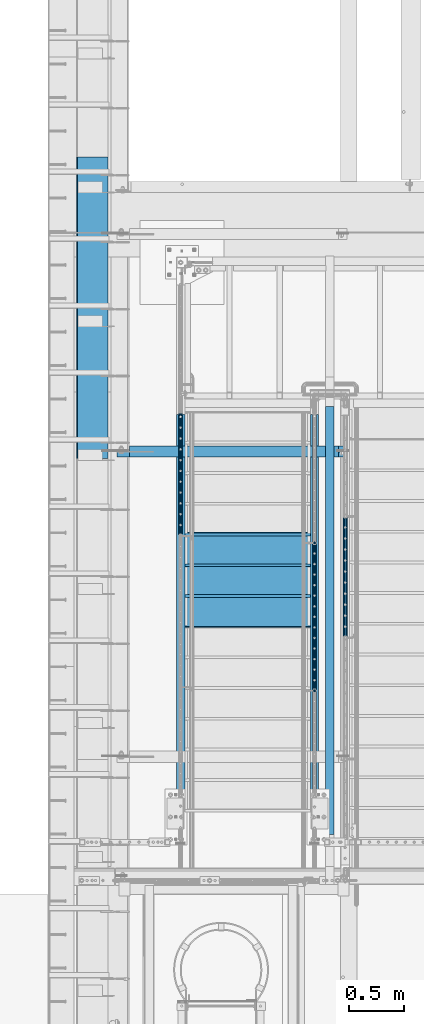
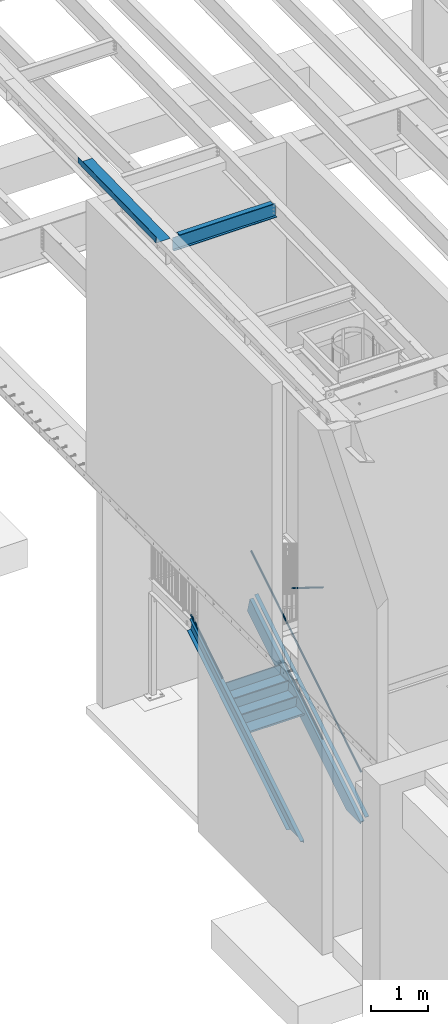
# One storey, part 1091 of 1763: 7 members, 5 beams, 7 elements without a shape of their own.
"""IFC2X3 building model written with IfcOpenShell, lengths in millimetres."""

import ifcopenshell
import ifcopenshell.guid

model = None  # the IFC model being written
_history = None  # IfcOwnerHistory: only IFC2X3 demands one
_inside = {}  # id of a spatial element -> (the spatial element, [elements in it])
_under = {}  # id of a project, library or spatial element -> (it, [spatial elements below it])
_declared = {}  # id of a project -> (the project, [libraries it declares])
_typed = {}  # id of a type object -> (the type object, [elements of that type])
_made_of = {}  # id of a material, layer set ... -> (it, [elements and type objects made of it])


def new_model(schema):
    """Start an empty IFC model of exactly this schema.

    Asked for "IFC4X3", IfcOpenShell would pick the latest addendum, in which some entities
    have other attributes; the version numbers below select the first issue.
    IFC2X3 requires an IfcOwnerHistory on every rooted entity: one is made here for all.
    """
    global model, _history
    if schema == "IFC4X3":
        model = ifcopenshell.file(schema_version=(4, 3, 0, 0))
    else:
        model = ifcopenshell.file(schema=schema)
    _inside.clear()
    _under.clear()
    _declared.clear()
    _typed.clear()
    _made_of.clear()
    _history = None
    if model.schema == "IFC2X3":
        org = make("IfcOrganization", Name="unknown")
        user = make(
            "IfcPersonAndOrganization",
            ThePerson=make("IfcPerson", FamilyName="unknown"),
            TheOrganization=org,
        )
        app = make(
            "IfcApplication",
            ApplicationDeveloper=org,
            Version="unknown",
            ApplicationFullName="unknown",
            ApplicationIdentifier="unknown",
        )
        _history = make(
            "IfcOwnerHistory",
            OwningUser=user,
            OwningApplication=app,
            ChangeAction="ADDED",
            CreationDate=0,
        )
    return model


def make(cls, **values):
    """One entity of the class cls with the attributes given. An attribute that is None is left unset."""
    return model.create_entity(
        cls, **{name: value for name, value in values.items() if value is not None}
    )


def rooted(cls, **values):
    """An entity with a GlobalId (a new one), such as an element, a storey or a relation."""
    return make(cls, GlobalId=ifcopenshell.guid.new(), OwnerHistory=_history, **values)


def si_unit(unit_type, name, prefix=None):
    """IfcSIUnit, for example si_unit("LENGTHUNIT", "METRE", prefix="MILLI")."""
    return make("IfcSIUnit", UnitType=unit_type, Prefix=prefix, Name=name)


def assignment(units):
    """IfcUnitAssignment: the units of a project."""
    return None if units is None else make("IfcUnitAssignment", Units=units)


def point(xyz):
    """IfcCartesianPoint."""
    return None if xyz is None else make("IfcCartesianPoint", Coordinates=xyz)


def direction(xyz):
    """IfcDirection."""
    return None if xyz is None else make("IfcDirection", DirectionRatios=xyz)


def frame(location, z_axis=None, x_axis=None):
    """IfcAxis2Placement3D, a coordinate frame: its origin and axes. An axis left out is left unset."""
    return make(
        "IfcAxis2Placement3D",
        Location=point(location),
        Axis=direction(z_axis),
        RefDirection=direction(x_axis),
    )


def origin_with_axes():
    """The frame at (0, 0, 0) with the z axis (0, 0, 1) and the x axis (1, 0, 0) written out."""
    return frame((0.0, 0.0, 0.0), z_axis=(0.0, 0.0, 1.0), x_axis=(1.0, 0.0, 0.0))


def place(relative_to, where):
    """IfcLocalPlacement: puts the frame where relative to a parent placement (None: the world)."""
    return make(
        "IfcLocalPlacement", PlacementRelTo=relative_to, RelativePlacement=where
    )


def context(
    kind, dimensions, precision=None, world=None, true_north=None, identifier=None
):
    """IfcGeometricRepresentationContext, for example the 3D "Model" context."""
    return make(
        "IfcGeometricRepresentationContext",
        ContextIdentifier=identifier,
        ContextType=kind,
        CoordinateSpaceDimension=dimensions,
        Precision=precision,
        WorldCoordinateSystem=world,
        TrueNorth=true_north,
    )


def subcontext(parent, identifier, kind, view, scale=None):
    """IfcGeometricRepresentationSubContext, for example "Body" below "Model"."""
    return make(
        "IfcGeometricRepresentationSubContext",
        ContextIdentifier=identifier,
        ContextType=kind,
        ParentContext=parent,
        TargetScale=scale,
        TargetView=view,
    )


def project(units=None, contexts=None):
    """IfcProject with its units and contexts."""
    return rooted(
        "IfcProject",
        Name="project",
        RepresentationContexts=contexts,
        UnitsInContext=assignment(units),
    )


def spatial(cls, under=None, at=None, **own):
    """A site, building, storey or space (cls), placed at a placement, below another one or the project."""
    s = rooted(cls, ObjectPlacement=at, **own)
    if under is not None:
        _under.setdefault(under.id(), (under, []))[1].append(s)
    return s


def faces_of(points, faces, orient=None, outer=None):
    """IfcFace entities. A face is a list of loops; a loop is a list of indices into points, from 0.

    orient and outer hold one flag for each loop. By default every Orientation is true, the
    first loop of a face is its IfcFaceOuterBound and the others are IfcFaceBound.
    """
    made = []
    for i, loops in enumerate(faces):
        bounds = []
        for j, loop in enumerate(loops):
            is_outer = j == 0 if outer is None else outer[i][j]
            bounds.append(
                make(
                    "IfcFaceOuterBound" if is_outer else "IfcFaceBound",
                    Bound=make("IfcPolyLoop", Polygon=[points[k] for k in loop]),
                    Orientation=True if orient is None else orient[i][j],
                )
            )
        made.append(make("IfcFace", Bounds=bounds))
    return made


def faceted_brep(points, faces, orient=None, outer=None, voids=None):
    """IfcFacetedBrep: a solid bounded by flat faces; with voids (closed shells), ...WithVoids."""
    shared = [point(p) for p in points]
    hull = make("IfcClosedShell", CfsFaces=faces_of(shared, faces, orient, outer))
    if voids is None:
        return make("IfcFacetedBrep", Outer=hull)
    return make(
        "IfcFacetedBrepWithVoids",
        Outer=hull,
        Voids=[
            make(cls, CfsFaces=faces_of(shared, fs, o, b)) for cls, fs, o, b in voids
        ],
    )


def shape(context_of_items, identifier, shape_type, items):
    """IfcShapeRepresentation: the items that make up one representation, for example the "Body"."""
    return make(
        "IfcShapeRepresentation",
        ContextOfItems=context_of_items,
        RepresentationIdentifier=identifier,
        RepresentationType=shape_type,
        Items=items,
    )


def material(Name=None, Category=None):
    """IfcMaterial."""
    return make("IfcMaterial", Name=Name, Category=Category)


def made_of(thing, what):
    """Note that an element or type object is made of a material, layer set ...; save() writes the relation."""
    if what is not None:
        _made_of.setdefault(what.id(), (what, []))[1].append(thing)
    return thing


def type_object(cls, material=None, **own):
    """A type object (cls), such as IfcWallType, which elements share."""
    return made_of(rooted(cls, **own), material)


def element(
    cls,
    number,
    at=None,
    inside=None,
    cuts=None,
    type_object=None,
    material=None,
    context=None,
    identifier="Body",
    shape_type=None,
    held_by="IfcProductDefinitionShape",
    body=None,
    shapes=None,
    **own,
):
    """One element of the class cls, such as IfcWall. Its Tag is "e" and its number.

    at: its placement. inside: the storey or other place that contains it. cuts: it is an
    opening in that element (IfcRelVoidsElement). A single representation is given by context,
    identifier, shape_type and body (its items); several are given by shapes. held_by: the class
    of the entity that holds the representations. save() writes the other relations.
    """
    e = rooted(cls, Tag="e%d" % number, ObjectPlacement=at, **own)
    if body is not None:
        shapes = [shape(context, identifier, shape_type, body)]
    if shapes is not None:
        e.Representation = make(held_by, Representations=shapes)
    if inside is not None:
        _inside.setdefault(inside.id(), (inside, []))[1].append(e)
    if cuts is not None:
        rooted(
            "IfcRelVoidsElement", RelatingBuildingElement=cuts, RelatedOpeningElement=e
        )
    if type_object is not None:
        _typed.setdefault(type_object.id(), (type_object, []))[1].append(e)
    return made_of(e, material)


def aggregate(whole, parts):
    """IfcRelAggregates: a whole, such as a stair, and the parts it consists of."""
    return rooted("IfcRelAggregates", RelatingObject=whole, RelatedObjects=parts)


def save(model, path):
    """Write the relations noted so far, then the file.

    IfcRelAggregates (storeys below a building ...), IfcRelContainedInSpatialStructure (elements
    in a storey), IfcRelDefinesByType, IfcRelAssociatesMaterial and IfcRelDeclares: one each for
    every whole, place, type object, material and project.
    """
    for whole, parts in _under.values():
        aggregate(whole, parts)
    for where, things in _inside.values():
        rooted(
            "IfcRelContainedInSpatialStructure",
            RelatedElements=things,
            RelatingStructure=where,
        )
    for kind, things in _typed.values():
        rooted("IfcRelDefinesByType", RelatedObjects=things, RelatingType=kind)
    for what, things in _made_of.values():
        rooted("IfcRelAssociatesMaterial", RelatedObjects=things, RelatingMaterial=what)
    for by, libraries in _declared.values():
        rooted("IfcRelDeclares", RelatingContext=by, RelatedDefinitions=libraries)
    model.write(path)


model = new_model("IFC2X3")

# Units and contexts
model_context = context("Model", 3, precision=1e-05, world=origin_with_axes())
body_context = subcontext(model_context, "Body", "Model", "MODEL_VIEW")
ifc_project = project(units=[si_unit("LENGTHUNIT", "METRE", prefix="MILLI"), si_unit("AREAUNIT", "SQUARE_METRE"), si_unit("VOLUMEUNIT", "CUBIC_METRE"), si_unit("MASSUNIT", "GRAM", prefix="KILO"), si_unit("TIMEUNIT", "SECOND"), si_unit("PLANEANGLEUNIT", "RADIAN"), si_unit("SOLIDANGLEUNIT", "STERADIAN"), si_unit("THERMODYNAMICTEMPERATUREUNIT", "DEGREE_CELSIUS"), si_unit("LUMINOUSINTENSITYUNIT", "LUMEN")], contexts=[model_context])

# Site, building, storey
site_placement = place(None, origin_with_axes())
site = spatial("IfcSite", under=ifc_project, at=site_placement, CompositionType="ELEMENT")
building_placement = place(site_placement, origin_with_axes())
building = spatial("IfcBuilding", under=site, at=building_placement, Name="Undefined", CompositionType="ELEMENT")
storey_placement = place(building_placement, origin_with_axes())
storey = spatial("IfcBuildingStorey", under=building, at=storey_placement, Name="Undefined", CompositionType="ELEMENT", Elevation=0.0)

# Assembly, members
assembly_1_placement = place(storey_placement, origin_with_axes())
assembly_1 = element("IfcElementAssembly", 1, at=assembly_1_placement, inside=storey, Name="RAIL", AssemblyPlace="NOTDEFINED", PredefinedType="RIGID_FRAME")
ifc_material_1 = material(Name="STEEL/A513")
member_type_1 = type_object("IfcMemberType", PredefinedType="NOTDEFINED")
member_1_placement = place(assembly_1_placement, frame((-85559.3372736887, 33401.0000003702, 1284.45777650386), z_axis=(0.0, -0.527268387919125, 0.849698797869673), x_axis=(0.0, 0.849698797869672, 0.527268387919126)))
member_1 = element("IfcMember", 2, at=member_1_placement, type_object=member_type_1, material=ifc_material_1, Name="RAIL", context=body_context, shape_type="Brep", body=[
    faceted_brep([(1575.14754564977, -9.52499999999418, 16.4977839397434), (1572.02558643742, -9.52499999551219, 11.4667123821018), (1572.58759299681, -7.68349999999919, 13.3082123776148), (1571.44218241748, 4.36557456851006e-11, 15.3669999976591), (1573.72761518211, 2.91038304567337e-11, 19.0499999976455), (1572.58759299399, 7.68349999999919, 13.3082123776148), (1572.02558643186, 9.52500000447617, 11.4667123731379), (1575.14754564977, 9.52499999999418, 16.4977839397434), (1584.32612048254, 19.0500000000029, -2.33194441534579e-09), (1579.02686783064, 16.4977839420899, 9.52499999765496), (1567.20566387564, 16.4977839420899, -9.52500000228974), (1574.13038414392, 13.3082123799541, 7.68349999766724), (1571.78546022086, 15.3669999999984, -2.31739250011742e-09), (1564.59461295365, 13.3082123799541, -7.68350000229111), (1557.794579011, 9.52500000447617, -11.4667123777472), (1554.67261979309, 9.52499999999418, -16.4977839443527), (1556.07115280309, 7.68349999999919, -13.3082123822205), (1552.37064003676, 0.0, -15.3670000022612), (1550.08520727212, 0.0, -19.0500000022475), (1557.79457900544, -9.52499999551219, -11.4667123867112), (1554.67261979309, -9.52499999999418, -16.4977839443527), (1556.07115280592, -7.68349999999919, -13.3082123822242), (1584.32612048011, -19.0499999955209, -8.18545231595635e-10), (1567.20566387564, -16.4977839420899, -9.52500000228974), (1579.02686783064, -16.4977839420899, 9.52499999765496), (1564.59461296419, -13.3082123799541, -7.68350000229111), (1571.7854602314, -15.3669999999984, -2.31739250011742e-09), (1574.13038415446, -13.3082123799541, 7.6834999976636), (5.29925264853227, -16.4977839420899, -9.52499999999418), (9.17857482939507, -9.52499999999418, -16.497783942079), (0.0, 19.0500000000029, 0.0), (5.29925264853227, 16.4977839420899, -9.52499999999418), (17.1204566035267, 16.4977839420899, 9.5249999999578), (29.6535006860868, 9.52499999999418, 16.4977839420208), (34.240913207057, 2.60333763435483e-08, 19.0499999999156), (9.17857482939507, 9.52499999999418, -16.497783942079), (10.5985052970609, 0.0, -19.0499999999811), (12.8839380616882, 0.0, -15.3669999999911), (12.3005340283707, -9.5249999739608, -11.4667124059888), (11.7385274769949, -7.68349999999919, -13.3082123799504), (11.7385274934168, 7.68349999999919, -13.3082123799504), (12.3005340606833, 9.52500002602756, -11.466712353922), (10.1957363620568, 13.3082123799541, -7.68350000000282), (12.5406602851217, 15.3669999999984, -1.81898940354586e-11), (19.7315075523256, 13.3082123799541, 7.68349999995917), (26.5315414548058, 9.52500002602756, 11.4667123538638), (28.2549676843155, 7.68349999999919, 13.3082123798886), (31.9554804424188, 2.60333763435483e-08, 15.3669999999256), (28.2549676678937, -7.68349999999919, 13.3082123798922), (26.5315414871147, -9.5249999739608, 11.4667124059306), (29.6535006860868, -9.52499999999418, 16.4977839420208), (17.1204566035267, -16.4977839420899, 9.5249999999578), (0.0, -19.0500000000029, 0.0), (19.7315074910439, -13.3082123799541, 7.68349999995917), (12.5406602238363, -15.3669999999984, -1.81898940354586e-11), (10.195736300775, -13.3082123799541, -7.68349999999919)], [[[0, 1, 2, 3, 4]], [[4, 3, 5, 6, 7]], [[8, 9, 10]], [[7, 6, 11, 12, 13, 14, 15, 10, 9]], [[16, 17, 18, 15, 14]], [[19, 20, 18, 17, 21]], [[22, 23, 24]], [[24, 23, 20, 19, 25, 26, 27, 1, 0]], [[28, 29, 20, 23]], [[30, 31, 32]], [[33, 34, 4, 7]], [[32, 33, 7, 9]], [[30, 32, 9, 8]], [[31, 30, 8, 10]], [[35, 31, 10, 15]], [[36, 35, 15, 18]], [[29, 36, 18, 20]], [[37, 36, 29, 38, 39]], [[40, 41, 35, 36, 37]], [[32, 31, 35, 41, 42, 43, 44, 45, 33]], [[33, 45, 46, 47, 34]], [[34, 47, 48, 49, 50]], [[34, 50, 0, 4]], [[50, 51, 24, 0]], [[51, 52, 22, 24]], [[52, 28, 23, 22]], [[51, 28, 52]], [[50, 49, 53, 54, 55, 38, 29, 28, 51]], [[54, 53, 27, 26]], [[55, 54, 26, 25]], [[21, 39, 38, 55, 25, 19]], [[37, 39, 21, 17]], [[40, 37, 17, 16]], [[42, 41, 40, 16, 14, 13]], [[43, 42, 13, 12]], [[44, 43, 12, 11]], [[5, 46, 45, 44, 11, 6]], [[47, 46, 5, 3]], [[48, 47, 3, 2]], [[53, 49, 48, 2, 1, 27]]]),
])
member_2_placement = place(assembly_1_placement, frame((-85559.3372737029, 35928.2999984601, 3798.88750001525), z_axis=(0.0, 0.527268387919125, -0.849698797869673), x_axis=(0.0, -0.849698797869672, -0.527268387919127)))
member_2 = element("IfcMember", 3, at=member_2_placement, type_object=member_type_1, material=ifc_material_1, Name="RAIL", context=body_context, shape_type="Brep", body=[
    faceted_brep([(4.71409293822944e-08, -15.3669999999984, 0.0), (2.19023042815024, -13.3082123799541, 7.68349999998281), (4554.39948192647, -13.3082123799541, 7.68349999416932), (4558.67421239756, -15.3669999999984, -5.82258508075029e-09), (3.79359040603231, -7.68349999999919, 13.3082123799213), (4551.27016203296, -7.68349999999919, 13.3082123741169), (4.38046088934425, 0.0, 15.3669999999638), (4550.12475145536, 0.0, 15.3669999941631), (3.79359040603231, 7.68349999999919, 13.3082123799213), (4551.27016203296, 7.68349999999919, 13.3082123741169), (2.19023042815024, 13.3082123799541, 7.68349999998281), (4554.39948192647, 13.3082123799541, 7.68349999416932), (4.71409293822944e-08, 15.3669999999984, 0.0), (4558.67421239756, 15.3669999999984, -5.82258508075029e-09), (-2.19023049421958, 13.3082123799541, -7.68349999998463), (4562.94894286867, 13.3082123799541, -7.68350000581449), (-3.793590472098, 7.68349999999919, -13.308212379925), (4566.07826276218, 7.68349999999919, -13.3082123857621), (-4.38046095540631, 0.0, -15.3669999999674), (4567.22367333977, 0.0, -15.3670000058028), (-3.793590472098, -7.68349999999919, -13.308212379925), (4566.07826276218, -7.68349999999919, -13.3082123857621), (-2.19023049421958, -13.3082123799541, -7.68349999998463), (4562.94894286867, -13.3082123799541, -7.68350000581449), (0.0, -19.0500000000029, 0.0), (-2.71516176177829, -16.4977839420899, -9.52499999998145), (4563.97346504769, -16.4977839420899, -9.52500000581313), (4558.67421239756, -19.0500000000029, -5.82258508075029e-09), (-4.70279809798376, -9.52499999999418, -16.4977839420626), (4567.85278722973, -9.52499999999418, -16.4977839478997), (-5.43032349052737, 0.0, -19.0499999999593), (4569.27271769782, 0.0, -19.0500000058), (-4.70279809798376, 9.52499999999418, -16.4977839420626), (4567.85278722973, 9.52499999999418, -16.4977839478997), (-2.71516176177829, 16.4977839420899, -9.52499999998145), (4563.97346504769, 16.4977839420899, -9.52500000581313), (0.0, 19.0500000000029, 0.0), (4558.67421239756, 19.0500000000029, -5.82258508075029e-09), (2.71516169570896, 16.4977839420899, 9.52499999997963), (4553.37495974744, 16.4977839420899, 9.52499999416796), (4.70279803191806, 9.52499999999418, 16.497783942059), (4549.4956375654, 9.52499999999418, 16.4977839362509), (5.43032342445076, 0.0, 19.0499999999611), (4548.07570709731, 0.0, 19.0499999941567), (4.70279803191806, -9.52499999999418, 16.497783942059), (4549.4956375654, -9.52499999999418, 16.4977839362509), (2.71516169570896, -16.4977839420899, 9.52499999997963), (4553.37495974744, -16.4977839420899, 9.52499999416796)], [[[0, 1, 2, 3]], [[1, 4, 5, 2]], [[4, 6, 7, 5]], [[6, 8, 9, 7]], [[8, 10, 11, 9]], [[10, 12, 13, 11]], [[12, 14, 15, 13]], [[14, 16, 17, 15]], [[16, 18, 19, 17]], [[18, 20, 21, 19]], [[20, 22, 23, 21]], [[22, 0, 3, 23]], [[24, 25, 26, 27]], [[25, 28, 29, 26]], [[28, 30, 31, 29]], [[30, 32, 33, 31]], [[32, 34, 35, 33]], [[34, 36, 37, 35]], [[36, 38, 39, 37]], [[38, 40, 41, 39]], [[40, 42, 43, 41]], [[42, 44, 45, 43]], [[44, 46, 47, 45]], [[46, 24, 27, 47]], [[29, 31, 33, 35, 37, 39, 41, 43, 45, 47, 27, 26], [5, 7, 9, 11, 13, 15, 17, 19, 21, 23, 3, 2]], [[46, 44, 42, 40, 38, 36, 34, 32, 30, 28, 25, 24], [22, 20, 18, 16, 14, 12, 10, 8, 6, 4, 1, 0]]]),
])
aggregate(assembly_1, [member_1, member_2])

# Assembly, member
assembly_2_placement = place(storey_placement, origin_with_axes())
assembly_2 = element("IfcElementAssembly", 4, at=assembly_2_placement, inside=storey, Name="RAIL", AssemblyPlace="NOTDEFINED", PredefinedType="RIGID_FRAME")
member_3_placement = place(assembly_2_placement, frame((-86778.5372737027, 34811.546667036, 2159.75225601796), z_axis=(0.0, -0.527268387919125, 0.849698797869673), x_axis=(0.0, 0.849698797869672, 0.527268387919126)))
member_3 = element("IfcMember", 5, at=member_3_placement, type_object=member_type_1, material=ifc_material_1, Name="RAIL", context=body_context, shape_type="Brep", body=[
    faceted_brep([(0.0, 19.0500000000029, 0.0), (5.29925264853227, 16.4977839420899, -9.52499999999418), (17.1204566035267, 16.4977839420899, 9.5249999999578), (17.1204566035267, -16.4977839420899, 9.5249999999578), (5.29925264853227, -16.4977839420899, -9.52499999999418), (0.0, -19.0500000000029, 0.0), (29.6535006860868, -9.52499999999418, 16.4977839420208), (26.5315414871147, -9.5249999739608, 11.4667124059306), (19.7315074910439, -13.3082123799541, 7.68349999995917), (12.5406602238363, -15.3669999999984, -1.81898940354586e-11), (10.195736300775, -13.3082123799541, -7.68349999999919), (12.3005340283707, -9.5249999739608, -11.4667124059888), (9.17857482939507, -9.52499999999418, -16.497783942079), (12.8839380616882, 0.0, -15.3669999999911), (10.5985052970609, 0.0, -19.0499999999811), (11.7385274769949, -7.68349999999919, -13.3082123799504), (11.7385274934168, 7.68349999999919, -13.3082123799504), (12.3005340606833, 9.52500002602756, -11.466712353922), (9.17857482939507, 9.52499999999418, -16.497783942079), (10.1957363620568, 13.3082123799541, -7.68350000000282), (12.5406602851217, 15.3669999999984, -1.81898940354586e-11), (19.7315075523256, 13.3082123799541, 7.68349999995917), (26.5315414548058, 9.52500002602756, 11.4667123538638), (29.6535006860868, 9.52499999999418, 16.4977839420208), (28.2549676843155, 7.68349999999919, 13.3082123798886), (31.9554804424188, 2.60333763435483e-08, 15.3669999999256), (34.240913207057, 2.60333763435483e-08, 19.0499999999156), (28.2549676678937, -7.68349999999919, 13.3082123798922), (1314.29317550014, -19.0500000000029, -1.68074620887637e-09), (1317.00833722889, -16.4977839420899, 9.52499999829888), (1318.9959735651, -9.52499999999418, 16.49778394038), (1319.72349895763, 0.0, 19.0499999982785), (1309.59037743519, -9.52499999999418, -16.4977839437379), (1311.57801377139, -16.4977839420899, -9.52500000166037), (1308.86285204265, 0.0, -19.05000000164), (1309.59037743519, 9.52499999999418, -16.4977839437379), (1311.57801377139, 16.4977839420899, -9.52500000166037), (1314.29317550014, 19.0500000000029, -1.68074620887637e-09), (1317.00833722889, 16.4977839420899, 9.52499999829888), (1318.9959735651, 9.52499999999418, 16.49778394038), (1318.0867659392, -7.68349999999919, 13.3082123782442), (1318.67363642252, 0.0, 15.3669999982849), (1318.0867659392, 7.68349999999919, 13.3082123782442), (1316.48340596133, 13.3082123799541, 7.68349999830025), (1314.29317550014, 15.3669999999984, -1.68074620887637e-09), (1312.10294503895, 13.3082123799541, -7.68350000166174), (1310.49958506108, 7.68349999999919, -13.3082123816093), (1309.91271457776, 0.0, -15.3670000016464), (1310.49958506108, -7.68349999999919, -13.3082123816093), (1312.10294503895, -13.3082123799541, -7.68350000166174), (1314.29317550014, -15.3669999999984, -1.68074620887637e-09), (1316.48340596133, -13.3082123799541, 7.68349999830025)], [[[0, 1, 2]], [[3, 4, 5]], [[6, 7, 8, 9, 10, 11, 12, 4, 3]], [[13, 14, 12, 11, 15]], [[16, 17, 18, 14, 13]], [[2, 1, 18, 17, 19, 20, 21, 22, 23]], [[23, 22, 24, 25, 26]], [[26, 25, 27, 7, 6]], [[28, 29, 3, 5]], [[29, 30, 6, 3]], [[30, 31, 26, 6]], [[32, 33, 4, 12]], [[34, 32, 12, 14]], [[35, 34, 14, 18]], [[36, 35, 18, 1]], [[37, 36, 1, 0]], [[38, 37, 0, 2]], [[39, 38, 2, 23]], [[31, 39, 23, 26]], [[33, 28, 5, 4]], [[32, 34, 35, 36, 37, 38, 39, 31, 30, 29, 28, 33], [40, 41, 42, 43, 44, 45, 46, 47, 48, 49, 50, 51]], [[42, 41, 25, 24]], [[21, 43, 42, 24, 22]], [[44, 43, 21, 20]], [[45, 44, 20, 19]], [[46, 45, 19, 17, 16]], [[47, 46, 16, 13]], [[48, 47, 13, 15]], [[49, 48, 15, 11, 10]], [[50, 49, 10, 9]], [[51, 50, 9, 8]], [[40, 51, 8, 7, 27]], [[41, 40, 27, 25]]]),
])
aggregate(assembly_2, [member_3])

assembly_3_placement = place(storey_placement, origin_with_axes())
assembly_3 = element("IfcElementAssembly", 6, at=assembly_3_placement, inside=storey, Name="RAIL", AssemblyPlace="NOTDEFINED", PredefinedType="RIGID_FRAME")
member_4_placement = place(assembly_3_placement, frame((-85279.8721005401, 34988.5000001836, 3467.73500019296), z_axis=(0.0, 0.527450977296466, 0.849585467477524), x_axis=(0.0, -0.849585467029397, 0.527450978018281)))
member_4 = element("IfcMember", 7, at=member_4_placement, type_object=member_type_1, material=ifc_material_1, Name="RAIL", context=body_context, shape_type="Brep", body=[
    faceted_brep([(1291.34034242866, -9.52499999999418, 16.4977839424391), (1288.21688551118, -9.52499998686835, 11.4667123934378), (1288.7793628039, -7.68349999999919, 13.3082123803069), (1287.63424189633, 1.30967237055302e-10, 15.3670000003513), (1289.92077106115, 1.16415321826935e-10, 19.0500000003412), (1288.77936279561, 7.68349999999919, 13.3082123803069), (1288.21688549488, 9.52500001312001, 11.4667123671861), (1291.34034242866, 9.52499999999418, 16.4977839424391), (1300.516596015, 19.0500000000029, 3.78349795937538e-10), (1295.21868352965, 16.4977839420899, 9.52500000035798), (1283.39180853924, 16.4977839420899, -9.52499999961219), (1290.32115089875, 13.3082123799541, 7.68350000035934), (1287.97426286884, 15.3669999999984, 3.71073838323355e-10), (1280.78080507319, 13.3082123799541, -7.6834999996172), (1273.97905098428, 9.52500001312001, -11.466712366444), (1270.8555940505, 9.52499999999418, -16.4977839417006), (1272.25499910396, 7.68349999999919, -13.3082123795684), (1268.55355024514, 0.0, -15.3669999996055), (1266.26702108033, 0.0, -19.0499999996027), (1273.97905096798, -9.52499998686835, -11.4667123926956), (1270.8555940505, -9.52499999999418, -16.4977839417006), (1272.25499911225, -7.68349999999919, -13.3082123795648), (1300.51659600284, -19.0499999868771, 7.93079379945993e-09), (1283.39180853924, -16.4977839420899, -9.52499999961219), (1295.21868352965, -16.4977839420899, 9.52500000035798), (1280.78080510413, -13.3082123799541, -7.6834999996172), (1287.97426289978, -15.3669999999984, 3.71073838323355e-10), (1290.32115092969, -13.3082123799541, 7.68350000035934), (5.29791245489469, -16.4977839420899, -9.52499999998327), (9.17625355589189, -9.52499999999418, -16.4977839420644), (0.0, 19.0500000000029, 0.0), (5.29791245489469, 16.4977839420899, -9.52499999998327), (17.1247874453111, 16.4977839420899, 9.52499999999054), (29.6610019340442, 9.52499999999418, 16.4977839420753), (34.2495749042173, 1.31403794512153e-08, 19.0499999999811), (9.17625355589189, 9.52499999999418, -16.4977839420644), (10.5958249233954, 0.0, -19.0499999999665), (12.8823540882113, 0.0, -15.3669999999693), (12.2997104733658, -9.5249999868538, -11.466712393074), (11.7372331812621, -7.68349999999919, -13.3082123799286), (11.7372331895313, 7.68349999999919, -13.3082123799286), (12.2997104896785, 9.52500001313456, -11.4667123667932), (10.1954450863705, 13.3082123799541, -7.683499999981), (12.542333116282, 15.3669999999984, 7.27595761418343e-12), (19.735790911931, 13.3082123799541, 7.68349999999555), (26.5375450002612, 9.52500001313456, 11.4667123668078), (28.2615968811733, 7.68349999999919, 13.3082123799431), (31.9630457394014, 1.31403794512153e-08, 15.3669999999838), (28.2615968729006, -7.68349999999919, 13.3082123799431), (26.5375450165775, -9.5249999868538, 11.4667123930885), (29.6610019340442, -9.52499999999418, 16.4977839420753), (17.1247874453111, -16.4977839420899, 9.52499999999054), (0.0, -19.0500000000029, 0.0), (19.7357908810409, -13.3082123799541, 7.68349999999555), (12.5423330853882, -15.3669999999984, 3.63797880709171e-12), (10.195445055484, -13.3082123799541, -7.68349999998463)], [[[0, 1, 2, 3, 4]], [[4, 3, 5, 6, 7]], [[8, 9, 10]], [[7, 6, 11, 12, 13, 14, 15, 10, 9]], [[16, 17, 18, 15, 14]], [[19, 20, 18, 17, 21]], [[22, 23, 24]], [[24, 23, 20, 19, 25, 26, 27, 1, 0]], [[28, 29, 20, 23]], [[30, 31, 32]], [[33, 34, 4, 7]], [[32, 33, 7, 9]], [[30, 32, 9, 8]], [[31, 30, 8, 10]], [[35, 31, 10, 15]], [[36, 35, 15, 18]], [[29, 36, 18, 20]], [[37, 36, 29, 38, 39]], [[40, 41, 35, 36, 37]], [[32, 31, 35, 41, 42, 43, 44, 45, 33]], [[33, 45, 46, 47, 34]], [[34, 47, 48, 49, 50]], [[34, 50, 0, 4]], [[50, 51, 24, 0]], [[51, 52, 22, 24]], [[52, 28, 23, 22]], [[51, 28, 52]], [[50, 49, 53, 54, 55, 38, 29, 28, 51]], [[54, 53, 27, 26]], [[55, 54, 26, 25]], [[21, 39, 38, 55, 25, 19]], [[37, 39, 21, 17]], [[40, 37, 17, 16]], [[42, 41, 40, 16, 14, 13]], [[43, 42, 13, 12]], [[44, 43, 12, 11]], [[5, 46, 45, 44, 11, 6]], [[47, 46, 5, 3]], [[48, 47, 3, 2]], [[53, 49, 48, 2, 1, 27]]]),
])
aggregate(assembly_3, [member_4])

# Assembly, members
assembly_4_placement = place(storey_placement, origin_with_axes())
assembly_4 = element("IfcElementAssembly", 8, at=assembly_4_placement, inside=storey, Name="STRINGER", AssemblyPlace="NOTDEFINED", PredefinedType="RIGID_FRAME")
ifc_material_2 = material(Name="STEEL/A36")
member_type_2 = type_object("IfcMemberType", Name="C12X20.7", PredefinedType="NOTDEFINED")
member_5_placement = place(assembly_4_placement, frame((-86778.5372737229, 35994.1748451654, 2653.39340745998), z_axis=(0.0, -0.527268387919125, 0.849698797869673), x_axis=(0.0, -0.849698797869672, -0.527268387919127)))
member_5 = element("IfcMember", 9, at=member_5_placement, type_object=member_type_2, material=ifc_material_2, Name="STRINGER", ObjectType="C12X20.7", context=body_context, shape_type="Brep", body=[
    faceted_brep([(86.8851842508811, -38.1000000000058, -152.400000000009), (85.0743522028934, -38.1000000000058, -146.047460000005), (81.8325404486168, 30.1625000000058, -134.6749275), (5.05264620630624, 30.1625000000058, 134.6749275), (1.81083327635861, -38.1000000000058, 146.04746), (0.0, -38.1000000000004, 152.4), (0.0, 38.1000000000004, 152.4), (86.885185425861, 38.1000000000058, -152.4), (4183.93933427285, 38.1000000000058, -152.399999997258), (4183.93933427285, -38.1000000000058, -152.399999997258), (4194.17652103875, -38.1000000000058, -146.047459997248), (4212.50347989358, 30.1625000000058, -134.674927497228), (4611.11897411009, 30.1625000000058, 112.680222852345), (4597.4704743535, 30.1625000000058, 134.674927503151), (4590.41341177765, -38.1000000000058, 146.047460003148), (4586.47143383249, -38.1000000000058, 152.400000003152), (4586.47143383249, 38.1000000000058, 152.400000003152), (4611.11897411009, 38.1000000000058, 112.680222852345)], [[[0, 1, 2, 3, 4, 5, 6, 7]], [[0, 7, 8, 9]], [[1, 0, 9, 10]], [[2, 1, 10, 11]], [[3, 2, 11, 12, 13]], [[4, 3, 13, 14]], [[5, 4, 14, 15]], [[6, 5, 15, 16]], [[8, 7, 6, 16, 17]], [[11, 10, 9, 8, 17, 12]], [[16, 15, 14, 13, 12, 17]]]),
])
member_6_placement = place(assembly_4_placement, frame((-85559.3372737343, 32143.9734063098, 264.20590747768), z_axis=(0.0, -0.527268387919125, 0.849698797869673), x_axis=(0.0, 0.849698797869672, 0.527268387919126)))
member_6 = element("IfcMember", 10, at=member_6_placement, type_object=member_type_2, material=ifc_material_2, Name="STRINGER", ObjectType="C12X20.7", context=body_context, shape_type="Brep", body=[
    faceted_brep([(4424.02203787379, -38.1000000000058, -146.047460002388), (4424.0220378738, -38.1000000000058, -152.400000002388), (4424.0220378738, 30.1624999999767, -152.400000002388), (4424.02203787376, 30.1625000000058, -134.674927502379), (4449.42203749235, 30.1625000000058, -134.67492750239), (4444.36939250549, 30.1625000000058, -152.400000002399), (4529.4437446872, -38.1000000000058, 146.047459997677), (4531.25457673519, -38.1000000000058, 152.399999997677), (-55.2168585121108, -38.1000000000058, 152.400000000092), (-59.1588364572672, -38.1000000000058, 146.047460000093), (4526.20193175603, 30.1625000000058, 134.674927497672), (-66.2158990331227, 30.1625000000058, 134.674927500091), (4444.36939250549, 38.1000000000058, -152.400000002399), (4531.25457673519, 38.1000000000058, 152.399999997677), (347.315242454777, -38.1000000000058, -152.400000000242), (347.315242454777, 38.1000000000058, -152.400000000242), (337.078055688882, -38.1000000000058, -146.047460000234), (318.75109683405, 30.1625000000058, -134.674927500218), (-79.8643983984985, 30.1625000000058, 112.680223479743), (-79.8643983984985, 38.1000000000058, 112.680223479743), (-55.2168585121108, 38.1000000000058, 152.400000000092)], [[[0, 1, 2, 3]], [[4, 3, 2, 5]], [[6, 7, 8, 9]], [[10, 6, 9, 11]], [[12, 13, 7, 6, 10, 4, 5]], [[1, 14, 15, 12, 5, 2]], [[16, 14, 1, 0]], [[17, 16, 0, 3]], [[15, 14, 16, 17, 18, 19]], [[13, 12, 15, 19, 20]], [[7, 13, 20, 8]], [[19, 18, 11, 9, 8, 20]], [[17, 3, 4, 10, 11, 18]]]),
])

# Assembly, member
assembly_5_placement = place(storey_placement, origin_with_axes())
assembly_5 = element("IfcElementAssembly", 11, at=assembly_5_placement, inside=storey, Name="ref.", AssemblyPlace="NOTDEFINED", PredefinedType="NOTDEFINED")
ifc_material_3 = material()
member_type_3 = type_object("IfcMemberType", PredefinedType="NOTDEFINED")
member_7_placement = place(assembly_5_placement, frame((-85419.6372736932, 35991.6932130395, 2780.1897063327), z_axis=(1.0, 0.0, 0.0), x_axis=(0.0, -0.849698797869672, -0.527268387919127)))
member_7 = element("IfcMember", 12, at=member_7_placement, type_object=member_type_3, material=ifc_material_3, Name="ref.", context=body_context, shape_type="Brep", body=[
    faceted_brep([(0.0, 3.17500000000018, -38.0999999999985), (0.0, 3.17500000000018, 38.0999999999985), (4586.47128389246, 3.17499999413849, 38.1000000000058), (4586.47128389246, 3.17499999413849, -38.1000000000058), (0.0, -3.17500000000018, 38.0999999999985), (4586.47128389244, -3.17500000584914, 38.1000000000058), (0.0, -3.17500000000018, -38.0999999999985), (4586.47128389244, -3.17500000584914, -38.1000000000058)], [[[0, 1, 2, 3]], [[1, 4, 5, 2]], [[4, 6, 7, 5]], [[6, 0, 3, 7]], [[5, 7, 3, 2]], [[6, 4, 1, 0]]]),
])
aggregate(assembly_5, [member_7])

# Beam
beam_type_1 = type_object("IfcBeamType", PredefinedType="NOTDEFINED")
beam_1_placement = place(assembly_4_placement, frame((-86168.937273734, 34836.099999984, 2036.98928571486), z_axis=(1.0, 0.0, 0.0), x_axis=(0.0, -1.0, 0.0)))
beam_1 = element("IfcBeam", 13, at=beam_1_placement, type_object=beam_type_1, material=ifc_material_2, Name="TREAD", context=body_context, shape_type="Brep", body=[
    faceted_brep([(0.0, -1.58749999999964, -571.5), (0.0, -1.58749999999964, 571.5), (0.0, 1.58749999999964, 571.5), (0.0, 1.58749999999964, -571.5), (21.7259680928437, 1.58749999999998, 571.5), (21.7259680928437, 1.58749999999998, -571.5), (25.3999996185303, -1.58749999999998, -571.5), (25.3999996185303, -1.58749999999998, 571.5), (-11.1162812923722, 225.765173339844, 571.5), (-11.1162812923722, 225.765173339844, -571.5), (-7.44224977493286, 222.590173339844, -571.5), (-7.44224977493286, 222.590173339844, 571.5), (293.683722205024, 225.765173339844, 571.5), (293.683722205024, 225.765173339844, -571.5), (290.939971923828, 222.590173339844, -571.5), (290.939971923828, 222.590173339844, 571.5), (299.604174562657, 185.35280002685, 571.5), (299.604174562657, 185.35280002685, -571.5), (296.462707519531, 184.892572021484, 571.5), (296.462707519531, 184.892572021484, -571.5)], [[[0, 1, 2, 3]], [[3, 2, 4, 5]], [[1, 0, 6, 7]], [[5, 4, 8, 9]], [[7, 6, 10, 11]], [[9, 8, 12, 13]], [[11, 10, 14, 15]], [[13, 12, 16, 17]], [[12, 8, 4, 2, 1, 7, 11, 15, 18, 16]], [[15, 14, 19, 18]], [[14, 10, 6, 0, 3, 5, 9, 13, 17, 19]], [[18, 19, 17, 16]]]),
])

beam_2_placement = place(assembly_4_placement, frame((-86168.937273734, 34556.699999984, 1863.61160714343), z_axis=(1.0, 0.0, 0.0), x_axis=(0.0, -1.0, 0.0)))
beam_2 = element("IfcBeam", 14, at=beam_2_placement, type_object=beam_type_1, material=ifc_material_2, Name="TREAD", context=body_context, shape_type="Brep", body=[
    faceted_brep([(0.0, -1.58749999999964, -571.5), (0.0, -1.58749999999964, 571.5), (0.0, 1.58749999999964, 571.5), (0.0, 1.58749999999964, -571.5), (21.7259680928437, 1.58749999999998, 571.5), (21.7259680928437, 1.58749999999998, -571.5), (25.3999996185303, -1.58749999999998, -571.5), (25.3999996185303, -1.58749999999998, 571.5), (-11.1162812923722, 225.765173339844, 571.5), (-11.1162812923722, 225.765173339844, -571.5), (-7.44224977493286, 222.590173339844, -571.5), (-7.44224977493286, 222.590173339844, 571.5), (293.683722205024, 225.765173339844, 571.5), (293.683722205024, 225.765173339844, -571.5), (290.939971923828, 222.590173339844, -571.5), (290.939971923828, 222.590173339844, 571.5), (299.604174562657, 185.35280002685, 571.5), (299.604174562657, 185.35280002685, -571.5), (296.462707519531, 184.892572021484, 571.5), (296.462707519531, 184.892572021484, -571.5)], [[[0, 1, 2, 3]], [[3, 2, 4, 5]], [[1, 0, 6, 7]], [[5, 4, 8, 9]], [[7, 6, 10, 11]], [[9, 8, 12, 13]], [[11, 10, 14, 15]], [[13, 12, 16, 17]], [[12, 8, 4, 2, 1, 7, 11, 15, 18, 16]], [[15, 14, 19, 18]], [[14, 10, 6, 0, 3, 5, 9, 13, 17, 19]], [[18, 19, 17, 16]]]),
])

beam_3_placement = place(assembly_4_placement, frame((-86168.937273734, 34277.299999984, 1690.233928572), z_axis=(1.0, 0.0, 0.0), x_axis=(0.0, -1.0, 0.0)))
beam_3 = element("IfcBeam", 15, at=beam_3_placement, type_object=beam_type_1, material=ifc_material_2, Name="TREAD", context=body_context, shape_type="Brep", body=[
    faceted_brep([(0.0, -1.58749999999964, -571.5), (0.0, -1.58749999999964, 571.5), (0.0, 1.58749999999964, 571.5), (0.0, 1.58749999999964, -571.5), (21.7259680928437, 1.58749999999998, 571.5), (21.7259680928437, 1.58749999999998, -571.5), (25.3999996185303, -1.58749999999998, -571.5), (25.3999996185303, -1.58749999999998, 571.5), (-11.1162812923722, 225.765173339844, 571.5), (-11.1162812923722, 225.765173339844, -571.5), (-7.44224977493286, 222.590173339844, -571.5), (-7.44224977493286, 222.590173339844, 571.5), (293.683722205024, 225.765173339844, 571.5), (293.683722205024, 225.765173339844, -571.5), (290.939971923828, 222.590173339844, -571.5), (290.939971923828, 222.590173339844, 571.5), (299.604174562657, 185.35280002685, 571.5), (299.604174562657, 185.35280002685, -571.5), (296.462707519531, 184.892572021484, 571.5), (296.462707519531, 184.892572021484, -571.5)], [[[0, 1, 2, 3]], [[3, 2, 4, 5]], [[1, 0, 6, 7]], [[5, 4, 8, 9]], [[7, 6, 10, 11]], [[9, 8, 12, 13]], [[11, 10, 14, 15]], [[13, 12, 16, 17]], [[12, 8, 4, 2, 1, 7, 11, 15, 18, 16]], [[15, 14, 19, 18]], [[14, 10, 6, 0, 3, 5, 9, 13, 17, 19]], [[18, 19, 17, 16]]]),
])

aggregate(assembly_4, [beam_1, beam_2, beam_3, member_5, member_6])

# Assembly, beam
assembly_6_placement = place(storey_placement, origin_with_axes())
assembly_6 = element("IfcElementAssembly", 16, at=assembly_6_placement, inside=storey, Name="BEAM", AssemblyPlace="NOTDEFINED", PredefinedType="RIGID_FRAME")
beam_type_2 = type_object("IfcBeamType", PredefinedType="NOTDEFINED")
beam_4_placement = place(assembly_6_placement, frame((-87438.9372736983, 36887.3869259865, 11435.5016133089), z_axis=(0.0, -0.999786037781472, -0.0206852279954809), x_axis=(-1.0, 0.0, 0.0)))
beam_4 = element("IfcBeam", 17, at=beam_4_placement, type_object=beam_type_2, material=ifc_material_2, Name="BENT_PLATE", context=body_context, shape_type="Brep", body=[
    faceted_brep([(2.91038304567337e-11, -3.17499999963729, -1371.60000000396), (-2.91038304567337e-11, -3.17500000036489, 1371.60000000395), (-2.91038304567337e-11, 3.17499999963184, 1371.60000000395), (2.91038304567337e-11, 3.17500000035943, -1371.60000000396), (285.75000000016, 3.17499999930078, 1371.59999999897), (285.750000000276, 3.17499999982283, -1371.59999999897), (279.400000000271, -3.1750000001648, -1371.59999999897), (279.400000000154, -3.17500000068321, 1371.59999999897), (285.750000000218, -123.824997298658, 1371.59999999895), (285.750000000218, -123.824997298212, -1371.59999999898), (279.400000000212, -123.824997298658, 1371.59999999895), (279.400000000212, -123.824997298212, -1371.59999999898)], [[[0, 1, 2, 3]], [[3, 2, 4, 5]], [[1, 0, 6, 7]], [[5, 4, 8, 9]], [[4, 2, 1, 7, 10, 8]], [[7, 6, 11, 10]], [[6, 0, 3, 5, 9, 11]], [[10, 11, 9, 8]]]),
])
aggregate(assembly_6, [beam_4])

assembly_7_placement = place(storey_placement, origin_with_axes())
assembly_7 = element("IfcElementAssembly", 18, at=assembly_7_placement, inside=storey, Name="BEAM", AssemblyPlace="NOTDEFINED", PredefinedType="RIGID_FRAME")
ifc_material_4 = material(Name="STEEL/A992")
beam_type_3 = type_object("IfcBeamType", Name="W12X22", PredefinedType="NOTDEFINED")
beam_5_placement = place(assembly_7_placement, frame((-87375.4372736983, 35579.05, 11249.6818944751), z_axis=(0.0, 0.0, 1.0), x_axis=(1.0, 0.0, 0.0)))
beam_5 = element("IfcBeam", 19, at=beam_5_placement, type_object=beam_type_3, material=ifc_material_4, Name="BEAM", ObjectType="W12X22", context=body_context, shape_type="Brep", body=[
    faceted_brep([(18.2562499999913, -3.17499999999927, -144.4625), (18.2562499999913, -50.7999999999993, -144.4625), (2109.67410714286, -50.7999999999993, -144.4625), (2109.67410714286, -3.17499999999927, -144.4625), (18.2562499999913, -50.7999999999993, -155.575000000001), (2109.67410714286, -50.7999999999993, -155.575000000001), (2109.67410714286, 3.17499999999927, -144.4625), (2109.67410714286, 50.7999999999993, -144.4625), (132.556249999994, 50.7999999999993, -144.4625), (132.556249999994, 3.17575008238782, -144.4625), (2033.47410714286, -50.7999999999993, 155.575000000001), (2033.47410714286, -50.7999999999993, 144.4625), (2033.47410714286, -3.17499999999927, 144.4625), (2033.47410714286, -3.17499999999927, 136.265001487105), (2033.47410714286, 3.17499999999927, 136.265001487105), (2033.47410714286, 3.17499999999927, 144.4625), (2033.47410714286, 50.7999999999993, 144.4625), (2033.47410714286, 50.7999999999993, 155.575000000001), (2034.44083706544, -3.17499999999927, 131.404921969059), (2034.44083706544, 3.17499999999927, 131.404921969059), (2037.19385096592, -3.17499999999927, 127.284745500905), (2037.19385096592, 3.17499999999927, 127.284745500905), (2041.31402743408, -3.17499999999927, 124.531731600428), (2041.31402743408, 3.17499999999927, 124.531731600428), (2046.17410695212, -3.17499999999927, 123.56500167784), (2046.17410695212, 3.17499999999927, 123.56500167784), (2109.67410714286, -3.17499999999927, 123.56500167784), (2109.67410714286, 3.17499999999927, 123.56500167784), (2109.67410714286, 50.7999999999993, -155.575000000001), (132.556249999994, 50.7999999999993, -155.575000000001), (132.556249999994, 3.17575008238782, -155.575000000001), (18.2562499999913, 3.17575008238782, -155.575000000001), (18.2562499999913, 3.17499999999927, -144.4625), (124.716329708754, -3.17499999999927, 105.741729925645), (124.716329708754, 3.17500736736474, 105.741729925645), (119.856250190714, 3.1750086254724, 104.775000003057), (119.856250190714, -3.17499999999927, 104.775000003057), (128.836506176915, -3.17499999999927, 108.494743826122), (128.836506176915, 3.17500378457771, 108.494743826122), (131.589520077396, -3.17499999999927, 112.614920294276), (131.589520077396, 3.17499842256075, 112.614920294276), (132.55624999998, -3.17499999999927, 117.474999812322), (132.55624999998, 3.17499209762536, 117.474999812322), (18.2562499999913, 3.17499999999927, -137.353076309833), (18.2562499999913, 3.17499999999927, 104.775000003057), (132.55624999998, 3.17499999999927, 144.4625), (132.55624999998, 50.7999999999993, 144.4625), (132.55624999998, 50.7999999999993, 155.575000000001), (132.55624999998, -50.7999999999993, 155.575000000001), (132.55624999998, -50.7999999999993, 144.4625), (132.55624999998, -3.17499999999927, 144.4625), (18.2562499999913, -3.17499999999927, 104.775000003057)], [[[0, 1, 2, 3]], [[1, 4, 5, 2]], [[6, 7, 8, 9]], [[10, 11, 12, 13, 14, 15, 16, 17]], [[18, 19, 14, 13]], [[20, 21, 19, 18]], [[22, 23, 21, 20]], [[24, 25, 23, 22]], [[26, 27, 25, 24]], [[3, 2, 5, 28, 7, 6, 27, 26]], [[7, 28, 29, 8]], [[8, 29, 30, 9]], [[28, 5, 4, 31, 30, 29]], [[9, 30, 31, 32]], [[33, 34, 35, 36]], [[37, 38, 34, 33]], [[39, 40, 38, 37]], [[41, 42, 40, 39]], [[15, 14, 19, 21, 23, 25, 27, 6, 9, 32, 43, 44, 35, 34, 38, 40, 42, 45]], [[16, 15, 45, 46]], [[17, 16, 46, 47]], [[10, 17, 47, 48]], [[11, 10, 48, 49]], [[12, 11, 49, 50]], [[48, 47, 46, 45, 42, 41, 50, 49]], [[39, 37, 33, 36, 51, 0, 3, 26, 24, 22, 20, 18, 13, 12, 50, 41]], [[43, 32, 31, 4, 1, 0, 51, 44]], [[36, 35, 44, 51]]]),
])
aggregate(assembly_7, [beam_5])

save(model, "model.ifc")
